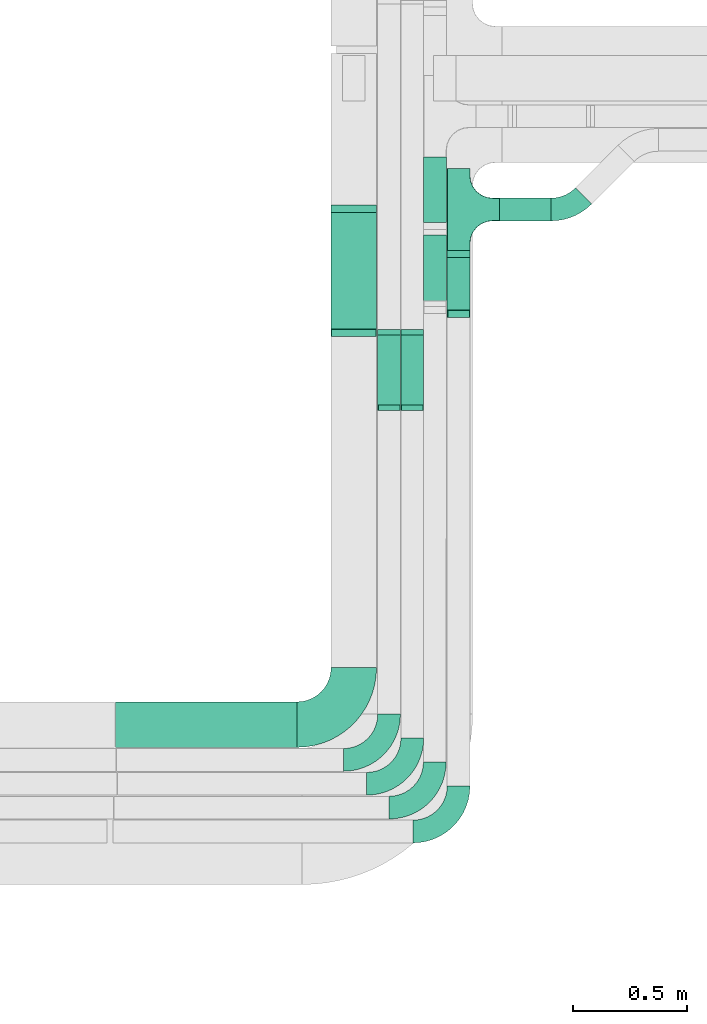
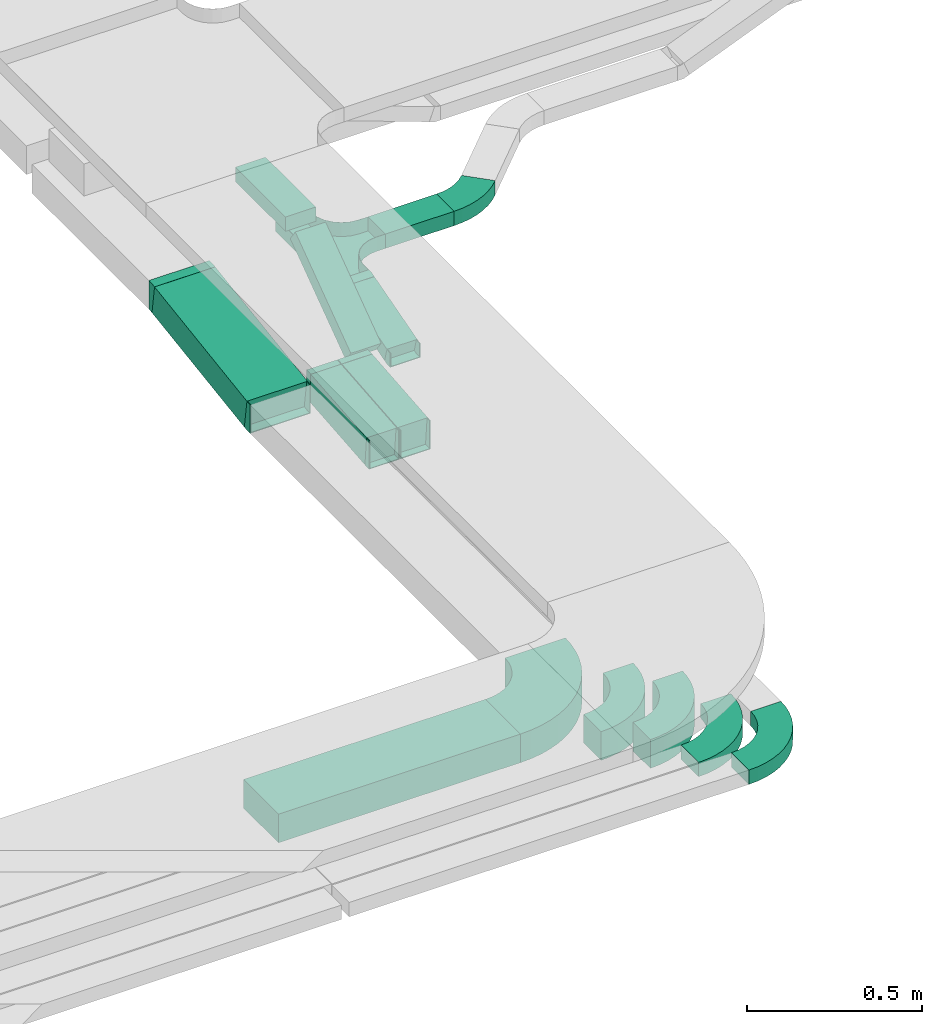
# One storey, part 30 of 38: 15 flow fittings, 8 flow segments.
"""IFC2X3 building model written with IfcOpenShell, lengths in millimetres."""

from ifc_helpers import new_model, entity, si_unit, converted_unit, derived_unit, direction, frame, frame_2d, origin, origin_2d_with_axis, place, context, subcontext, project, spatial, polyline, circle_curve, parameter, trimmed, segment, composite_curve, rectangle, outline, extrude, faceted_brep, source, transform, mapped, material, type_object, type_shapes, element, save


model = new_model("IFC2X3")

# Units and contexts
model_context = context("Model", 3, precision=0.01, world=origin(), true_north=direction((6.12303176911189e-17, 1.0)))
body_context = subcontext(model_context, "Body", "Model", "MODEL_VIEW")
ifc_project = project(units=[si_unit("LENGTHUNIT", "METRE", prefix="MILLI"), si_unit("AREAUNIT", "SQUARE_METRE"), si_unit("VOLUMEUNIT", "CUBIC_METRE"), converted_unit("PLANEANGLEUNIT", "DEGREE", entity("IfcRatioMeasure", 0.0174532925199433), si_unit("PLANEANGLEUNIT", "RADIAN"), dimensions=[0, 0, 0, 0, 0, 0, 0]), si_unit("MASSUNIT", "GRAM", prefix="KILO"), derived_unit("MASSDENSITYUNIT", [(si_unit("MASSUNIT", "GRAM", prefix="KILO"), 1), (si_unit("LENGTHUNIT", "METRE"), -3)]), derived_unit("MOMENTOFINERTIAUNIT", [(si_unit("LENGTHUNIT", "METRE"), 4)]), si_unit("TIMEUNIT", "SECOND"), si_unit("FREQUENCYUNIT", "HERTZ"), si_unit("THERMODYNAMICTEMPERATUREUNIT", "DEGREE_CELSIUS"), derived_unit("THERMALTRANSMITTANCEUNIT", [(si_unit("MASSUNIT", "GRAM", prefix="KILO"), 1), (si_unit("THERMODYNAMICTEMPERATUREUNIT", "KELVIN"), -1), (si_unit("TIMEUNIT", "SECOND"), -3)]), derived_unit("VOLUMETRICFLOWRATEUNIT", [(si_unit("LENGTHUNIT", "METRE"), 3), (si_unit("TIMEUNIT", "SECOND"), -1)]), derived_unit("MASSFLOWRATEUNIT", [(si_unit("MASSUNIT", "GRAM", prefix="KILO"), 1), (si_unit("TIMEUNIT", "SECOND"), -1)]), derived_unit("ROTATIONALFREQUENCYUNIT", [(si_unit("TIMEUNIT", "SECOND"), -1)]), si_unit("ELECTRICCURRENTUNIT", "AMPERE"), si_unit("ELECTRICVOLTAGEUNIT", "VOLT"), si_unit("POWERUNIT", "WATT"), si_unit("FORCEUNIT", "NEWTON", prefix="KILO"), si_unit("ILLUMINANCEUNIT", "LUX"), si_unit("LUMINOUSFLUXUNIT", "LUMEN"), si_unit("LUMINOUSINTENSITYUNIT", "CANDELA"), derived_unit("USERDEFINED", [(si_unit("MASSUNIT", "GRAM", prefix="KILO"), -1), (si_unit("LENGTHUNIT", "METRE"), -2), (si_unit("TIMEUNIT", "SECOND"), 3), (si_unit("LUMINOUSFLUXUNIT", "LUMEN"), 1)]), derived_unit("LINEARVELOCITYUNIT", [(si_unit("LENGTHUNIT", "METRE"), 1), (si_unit("TIMEUNIT", "SECOND"), -1)]), si_unit("PRESSUREUNIT", "PASCAL"), derived_unit("USERDEFINED", [(si_unit("LENGTHUNIT", "METRE"), -2), (si_unit("MASSUNIT", "GRAM", prefix="KILO"), 1), (si_unit("TIMEUNIT", "SECOND"), -2)]), derived_unit("LINEARFORCEUNIT", [(si_unit("MASSUNIT", "GRAM", prefix="KILO"), 1), (si_unit("LENGTHUNIT", "METRE"), 1), (si_unit("TIMEUNIT", "SECOND"), -2), (si_unit("LENGTHUNIT", "METRE"), -1)]), derived_unit("PLANARFORCEUNIT", [(si_unit("MASSUNIT", "GRAM", prefix="KILO"), 1), (si_unit("LENGTHUNIT", "METRE"), 1), (si_unit("TIMEUNIT", "SECOND"), -2), (si_unit("LENGTHUNIT", "METRE"), -2)])], contexts=[model_context])

# Site, building, storey
site_placement = place(None, frame((0.0, -0.00077364408347762, 0.0)))
site = spatial("IfcSite", under=ifc_project, at=site_placement, CompositionType="ELEMENT")
building_placement = place(site_placement, origin())
building = spatial("IfcBuilding", under=site, at=building_placement, CompositionType="ELEMENT")
storey_placement = place(building_placement, frame((0.0, 0.0, 4200.0)))
storey = spatial("IfcBuildingStorey", under=building, at=storey_placement, CompositionType="ELEMENT", Elevation=4200.0)

# Flow segments
cable_carrier_segment_type = type_object("IfcCableCarrierSegmentType", PredefinedType="CABLETRAYSEGMENT")
flow_segment_1_placement = place(storey_placement, frame((60521.4530273012, 5820.36768039066, 2500.0)))
element("IfcFlowSegment", 1, at=flow_segment_1_placement, inside=storey, type_object=cable_carrier_segment_type, context=body_context, shape_type="SweptSolid", body=[
    extrude(rectangle(XDim=798.730000005086, YDim=200.0, at=frame_2d((0.0, -5.47117906535277e-13), x_axis=(1.0, 0.0))), frame((399.365000002543, 100.0, 0.0)), (0.0, 0.0, 1.0), 99.9999999999989),
])
flow_segment_2_placement = place(storey_placement, frame((61982.1830273061, 7730.19297696232, 2504.47725110402)))
element("IfcFlowSegment", 2, at=flow_segment_2_placement, inside=storey, type_object=cable_carrier_segment_type, context=body_context, shape_type="SweptSolid", body=[
    extrude(rectangle(XDim=49.9999999999994, YDim=255.01050846726, at=frame_2d((-6.60804744256893e-13, -3.69482222595252e-13), x_axis=(0.0, 1.0))), frame((0.0, 129.456850821088, 59.1767535282115), z_axis=(1.0, 0.0, 0.0), x_axis=(0.0, 0.961261695938266, 0.275637355817185)), (0.0, 0.0, 1.0), 99.9999999999945),
])
flow_segment_3_placement = place(storey_placement, frame((61878.3352641976, 8130.36201332961, 2757.63390080053)))
element("IfcFlowSegment", 3, at=flow_segment_3_placement, inside=storey, type_object=cable_carrier_segment_type, context=body_context, shape_type="SweptSolid", body=[
    extrude(rectangle(XDim=287.085953827233, YDim=99.9999999999946, at=frame_2d((-5.40012479177676e-13, 0.0), x_axis=(1.0, 0.0))), frame((50.0, 143.543000678446, 6.8225538865363e-05), z_axis=(0.0, -4.75296948219352e-07, 1.0), x_axis=(0.0, -1.0, -4.75296948219352e-07)), (0.0, 0.0, 1.0), 49.9999999999943),
])
flow_segment_4_placement = place(storey_placement, frame((61878.3352641976, 7756.69685752095, 2518.21756635997)))
element("IfcFlowSegment", 4, at=flow_segment_4_placement, inside=storey, type_object=cable_carrier_segment_type, context=body_context, shape_type="SweptSolid", body=[
    extrude(rectangle(XDim=50.0000000000008, YDim=392.571805962097, at=frame_2d((-4.40536496171262e-13, 3.19744231092045e-13), x_axis=(0.0, 1.0))), frame((0.0, 173.493262575214, 135.599383864544), z_axis=(1.0, 0.0, 0.0), x_axis=(0.0, -0.809016994374955, -0.587785252292463)), (0.0, 0.0, 1.0), 99.9999999999946),
])
flow_segment_5_placement = place(storey_placement, frame((61778.6830273062, 7317.30512280422, 2501.08924105085)))
element("IfcFlowSegment", 5, at=flow_segment_5_placement, inside=storey, type_object=cable_carrier_segment_type, context=body_context, shape_type="SweptSolid", body=[
    extrude(rectangle(XDim=99.9999999999994, YDim=99.9999999999946, at=frame_2d((0.0, 5.32907051820075e-14), x_axis=(0.0, 1.0))), frame((50.0, 4.5268117197936, 49.794658103591), z_axis=(0.0, 0.995893162071827, 0.0905362343958401), x_axis=(-1.0, 0.0, 0.0)), (0.0, 0.0, 1.0), 319.917187827381),
])
flow_segment_6_placement = place(storey_placement, frame((61676.2835022257, 7317.30086783851, 2501.08924105085)))
element("IfcFlowSegment", 6, at=flow_segment_6_placement, inside=storey, type_object=cable_carrier_segment_type, context=body_context, shape_type="SweptSolid", body=[
    extrude(rectangle(XDim=99.9999999999994, YDim=99.9999999999946, at=frame_2d((0.0, 5.32907051820075e-14), x_axis=(0.0, 1.0))), frame((50.0, 4.52681171979143, 49.7946581035921), z_axis=(0.0, 0.995893162071827, 0.0905362343958401), x_axis=(-1.0, 0.0, 0.0)), (0.0, 0.0, 1.0), 319.925697831031),
])
flow_segment_7_placement = place(storey_placement, frame((61471.1830273063, 7645.6392623105, 2502.43623020296)))
element("IfcFlowSegment", 7, at=flow_segment_7_placement, inside=storey, type_object=cable_carrier_segment_type, context=body_context, shape_type="SweptSolid", body=[
    extrude(rectangle(XDim=99.9999999999998, YDim=533.962924663429, at=frame_2d((0.0, 0.0), x_axis=(0.0, 1.0))), frame((0.0, 271.43744470685, 88.8637697970419), z_axis=(1.0, 0.0, 0.0), x_axis=(0.0, 0.989044291278135, 0.147619070211579)), (0.0, 0.0, 1.0), 200.000000000006),
])
flow_segment_8_placement = place(storey_placement, frame((62212.1830273061, 8137.18210775869, 2577.30800926447)))
element("IfcFlowSegment", 8, at=flow_segment_8_placement, inside=storey, type_object=cable_carrier_segment_type, context=body_context, shape_type="SweptSolid", body=[
    extrude(rectangle(XDim=226.520887797976, YDim=99.9999999999989, at=origin_2d_with_axis()), frame((113.260443898988, 50.0, 0.0)), (0.0, 0.0, 1.0), 49.9999999999995),
])

# Flow fittings
ifc_material = material()
cable_carrier_fitting_type_1 = type_object("IfcCableCarrierFittingType", Name="470_DKC_S5_Variable Angle Elbow 0-45:-", PredefinedType="NOTDEFINED", material=ifc_material)
shared_shape_1 = source(origin(), body_context, "Body", "SweptSolid", [
    extrude(outline(composite_curve([segment(polyline([(-125.750000000001, -225.25), (-124.749999999999, -225.25)]), True, "CONTINUOUS"), segment(trimmed(circle_curve(frame_2d((-124.75, 124.75), x_axis=(0.0, -1.0)), 350.0), [parameter(0.0)], [parameter(90.0000000000001)], True, "PARAMETER"), True, "CONTINUOUS"), segment(polyline([(225.25, 124.75), (225.25, 125.749999999999)]), True, "CONTINUOUS"), segment(polyline([(225.25, 125.749999999999), (25.25, 125.750000000001)]), True, "CONTINUOUS"), segment(polyline([(25.25, 125.750000000001), (25.25, 124.75)]), True, "CONTINUOUS"), segment(trimmed(circle_curve(frame_2d((-124.75, 124.75), x_axis=(0.0, -1.0)), 150.0), [parameter(0.0)], [parameter(90.0000000000001)], True, "PARAMETER"), False, "CONTINUOUS"), segment(polyline([(-124.749999999999, -25.2500000000003), (-125.750000000001, -25.2500000000003)]), True, "CONTINUOUS"), segment(polyline([(-125.750000000001, -25.2500000000003), (-125.750000000001, -225.25)]), True, "CONTINUOUS")], self_intersect=False)), frame((-125.249999999991, 125.249999999992, -50.0)), (0.0, 0.0, 1.0), 100.0),
])
type_shapes(cable_carrier_fitting_type_1, [shared_shape_1])
flow_fitting_1_placement = place(storey_placement, frame((61571.1830273063, 5920.36768039068, 2550.0)))
element("IfcFlowFitting", 9, at=flow_fitting_1_placement, inside=storey, type_object=cable_carrier_fitting_type_1, material=ifc_material, Name="470_DKC_S5_Variable Angle Elbow 0-45:-", ObjectType="470_DKC_S5_Variable Angle Elbow 0-45:-", context=body_context, shape_type="MappedRepresentation", body=[
    mapped(shared_shape_1, transform((0.0, 0.0, 0.0), scale=1.0)),
])
cable_carrier_fitting_type_2 = type_object("IfcCableCarrierFittingType", Name="470_DKC_S5_Variable Angle Elbow 0-45:-", PredefinedType="NOTDEFINED", material=ifc_material)
shared_shape_2 = source(origin(), body_context, "Body", "SweptSolid", [
    extrude(outline(composite_curve([segment(polyline([(-100.749999999999, -150.250000000001), (-99.7499999999981, -150.250000000001)]), True, "CONTINUOUS"), segment(trimmed(circle_curve(frame_2d((-99.7500000000006, 99.7499999999987), x_axis=(0.0, -1.0)), 250.0), [parameter(0.0)], [parameter(90.0000000000001)], True, "PARAMETER"), True, "CONTINUOUS"), segment(polyline([(150.249999999999, 99.7500000000013), (150.249999999999, 100.750000000001)]), True, "CONTINUOUS"), segment(polyline([(150.249999999999, 100.750000000001), (50.2499999999992, 100.750000000001)]), True, "CONTINUOUS"), segment(polyline([(50.2499999999992, 100.750000000001), (50.2499999999992, 99.7500000000002)]), True, "CONTINUOUS"), segment(trimmed(circle_curve(frame_2d((-99.7500000000006, 99.7499999999987), x_axis=(0.0, -1.0)), 150.0), [parameter(0.0)], [parameter(90.0000000000001)], True, "PARAMETER"), False, "CONTINUOUS"), segment(polyline([(-99.7499999999989, -50.2500000000011), (-100.75, -50.2500000000011)]), True, "CONTINUOUS"), segment(polyline([(-100.75, -50.2500000000011), (-100.749999999999, -150.250000000001)]), True, "CONTINUOUS")], self_intersect=False)), frame((-100.249999999991, 100.249999999992, -50.0)), (0.0, 0.0, 1.0), 100.0),
])
type_shapes(cable_carrier_fitting_type_2, [shared_shape_2])
for number, where, name in (
    (10, (61828.6830273062, 5660.19378076407, 2550.0), "470_DKC_S5_Variable Angle Elbow 0-45:-"),
    (11, (61726.2835022257, 5765.19378076406, 2550.0), "470_DKC_S5_Variable Angle Elbow 0-45:-"),
):
    element("IfcFlowFitting", number, at=place(storey_placement, frame(where)), inside=storey, type_object=cable_carrier_fitting_type_2, material=ifc_material, Name=name, ObjectType="470_DKC_S5_Variable Angle Elbow 0-45:-", context=body_context, shape_type="MappedRepresentation", body=[
        mapped(shared_shape_2, transform((0.0, 0.0, 0.0), scale=1.0)),
    ])
cable_carrier_fitting_type_3 = type_object("IfcCableCarrierFittingType", PredefinedType="NOTDEFINED", material=ifc_material)
shared_shape_3 = source(origin(), body_context, "Body", "Brep", [
    faceted_brep([(-53.4074173710859, -124.118095489752, 25.0), (-50.0, -150.0, 25.0), (-50.0, -180.0, 25.0), (-49.1999999999934, -180.0, 25.0), (-49.1999999999926, -150.0, 25.0), (-52.6346767100545, -123.91104025367, 25.0), (-62.7046392985216, -99.6000000000037, 25.0), (-78.7236364563899, -78.7236364563991, 25.0), (-99.5999999999949, -62.7046392985315, 25.0), (-123.911040253662, -52.6346767100651, 25.0), (-150.0, -49.2000000000047, 25.0), (-180.0, -49.2000000000047, 25.0), (-180.0, -50.0, 25.0), (-150.0, -50.0, 25.0), (-124.118095489745, -53.4074173710983, 25.0), (-100.0, -63.3974596215602, 25.0), (-79.2893218813398, -79.2893218813488, 25.0), (-63.3974596215496, -100.0, 25.0), (180.0, -50.0, 25.0), (180.0, -49.2000000000047, 25.0), (150.0, -49.2000000000046, 25.0), (123.911040253717, -52.634676710066, 25.0), (99.6000000000452, -62.7046392985316, 25.0), (78.7236364564342, -78.7236364563979, 25.0), (62.7046392985581, -99.6000000000012, 25.0), (52.6346767100809, -123.911040253668, 25.0), (49.200000000007, -150.0, 25.0), (49.2000000000071, -180.0, 25.0), (50.0, -180.0, 25.0), (50.0, -150.0, 25.0), (53.4074173711136, -124.11809548975, 25.0), (63.3974596215874, -100.0, 25.0), (79.2893218813853, -79.2893218813486, 25.0), (100.0, -63.3974596215613, 25.0), (124.1180954898, -53.4074173710999, 25.0), (150.0, -50.0, 25.0), (180.0, 49.1999999999958, 25.0), (180.0, 50.0, 25.0), (-180.0, 50.0, 25.0), (-180.0, 49.1999999999958, 25.0), (-180.0, -50.0, -25.0), (-180.0, 50.0, -25.0), (180.0, 50.0, -25.0), (180.0, -50.0, -25.0), (150.0, -50.0, -25.0), (124.1180954898, -53.4074173710999, -25.0), (100.0, -63.3974596215613, -25.0), (79.2893218813853, -79.2893218813486, -25.0), (63.3974596215874, -100.0, -25.0), (53.4074173711136, -124.11809548975, -25.0), (50.0, -150.0, -25.0), (50.0, -180.0, -25.0), (-50.0, -180.0, -25.0), (-50.0, -150.0, -25.0), (-53.4074173710859, -124.118095489752, -25.0), (-63.3974596215496, -100.0, -25.0), (-79.2893218813398, -79.2893218813488, -25.0), (-100.0, -63.3974596215602, -25.0), (-124.118095489745, -53.4074173710983, -25.0), (-150.0, -50.0, -25.0), (-50.0, -150.0, -24.199999999986), (49.2000000000071, -180.0, -24.199999999986), (-49.1999999999934, -180.0, -24.199999999986), (-49.1999999999926, -150.0, -24.199999999986), (-150.0, -49.2000000000047, -24.199999999986), (-180.0, -49.2000000000047, -24.199999999986), (180.0, -49.2000000000047, -24.199999999986), (150.0, -49.2000000000047, -24.199999999986), (-180.0, 49.1999999999958, -24.199999999986), (-150.0, -50.0, -24.199999999986), (150.0, -50.0, -24.199999999986), (180.0, 49.1999999999958, -24.199999999986), (49.200000000007, -150.0, -24.199999999986), (50.0, -150.0, -24.199999999986), (-123.911040253662, -52.6346767100651, -24.199999999986), (-99.5999999999949, -62.7046392985315, -24.199999999986), (-78.7236364563899, -78.7236364563991, -24.199999999986), (-62.7046392985217, -99.6000000000036, -24.199999999986), (-52.6346767100546, -123.91104025367, -24.199999999986), (52.6346767100807, -123.911040253669, -24.199999999986), (62.7046392985577, -99.6000000000018, -24.199999999986), (78.7236364564338, -78.7236364563983, -24.199999999986), (99.6000000000446, -62.704639298532, -24.199999999986), (123.911040253716, -52.6346767100662, -24.199999999986)], [[[0, 1, 2, 3, 4, 5, 6, 7, 8, 9, 10, 11, 12, 13, 14, 15, 16, 17]], [[18, 19, 20, 21, 22, 23, 24, 25, 26, 27, 28, 29, 30, 31, 32, 33, 34, 35]], [[36, 37, 38, 39]], [[40, 41, 42, 43, 44, 45, 46, 47, 48, 49, 50, 51, 52, 53, 54, 55, 56, 57, 58, 59]], [[2, 1, 60, 53, 52]], [[3, 2, 52, 51, 28, 27, 61, 62]], [[4, 3, 62, 63]], [[11, 10, 64, 65]], [[20, 19, 66, 67]], [[39, 38, 41, 40, 12, 11, 65, 68]], [[13, 12, 40, 59, 69]], [[18, 35, 70, 44, 43]], [[19, 18, 43, 42, 37, 36, 71, 66]], [[27, 26, 72, 61]], [[29, 28, 51, 50, 73]], [[38, 37, 42, 41]], [[36, 39, 68, 71]], [[68, 65, 64, 74, 75, 76, 77, 78, 63, 62, 61, 72, 79, 80, 81, 82, 83, 67, 66, 71]], [[14, 13, 69, 59, 58]], [[58, 57, 15, 14]], [[15, 57, 56, 16]], [[0, 17, 55, 54]], [[0, 54, 53, 60, 1]], [[55, 17, 16, 56]], [[5, 4, 63, 78]], [[6, 5, 78, 77]], [[7, 6, 77, 76]], [[8, 7, 76, 75]], [[9, 8, 75, 74]], [[10, 9, 74, 64]], [[21, 20, 67, 83]], [[22, 21, 83, 82]], [[23, 22, 82, 81]], [[81, 80, 24, 23]], [[24, 80, 79, 25]], [[79, 72, 26, 25]], [[30, 29, 73, 50, 49]], [[31, 30, 49, 48]], [[31, 48, 47, 32]], [[33, 32, 47, 46]], [[45, 34, 33, 46]], [[34, 45, 44, 70, 35]]]),
])
type_shapes(cable_carrier_fitting_type_3, [shared_shape_3])
flow_fitting_2_placement = place(storey_placement, frame((62032.1830273061, 8187.18210775868, 2602.30800926447), z_axis=(0.0, 0.0, 1.0), x_axis=(0.0, 1.0, 0.0)))
element("IfcFlowFitting", 12, at=flow_fitting_2_placement, inside=storey, type_object=cable_carrier_fitting_type_3, material=ifc_material, Name="470_DKC_S5_T", context=body_context, shape_type="MappedRepresentation", body=[
    mapped(shared_shape_3, transform((0.0, 0.0, 0.0), scale=1.0)),
])
cable_carrier_fitting_type_4 = type_object("IfcCableCarrierFittingType", Name="470_DKC_S5_Variable Angle Elbow 0-45:-", PredefinedType="NOTDEFINED", material=ifc_material)
shared_shape_4 = source(origin(), body_context, "Body", "SweptSolid", [
    extrude(outline(composite_curve([segment(polyline([(-100.750000000001, -150.25), (-99.7499999999994, -150.25)]), True, "CONTINUOUS"), segment(trimmed(circle_curve(frame_2d((-99.7499999999997, 99.7499999999995), x_axis=(0.0, -1.0)), 250.0), [parameter(0.0)], [parameter(90.0000000000001)], True, "PARAMETER"), True, "CONTINUOUS"), segment(polyline([(150.25, 99.75), (150.25, 100.749999999999)]), True, "CONTINUOUS"), segment(polyline([(150.25, 100.749999999999), (50.25, 100.75)]), True, "CONTINUOUS"), segment(polyline([(50.25, 100.75), (50.25, 99.7499999999998)]), True, "CONTINUOUS"), segment(trimmed(circle_curve(frame_2d((-99.7499999999997, 99.7499999999995), x_axis=(0.0, -1.0)), 150.0), [parameter(0.0)], [parameter(90.0000000000001)], True, "PARAMETER"), False, "CONTINUOUS"), segment(polyline([(-99.7499999999994, -50.2500000000003), (-100.750000000001, -50.2500000000003)]), True, "CONTINUOUS"), segment(polyline([(-100.750000000001, -50.2500000000003), (-100.750000000001, -150.25)]), True, "CONTINUOUS")], self_intersect=False)), frame((-100.249999999991, 100.249999999992, -25.0)), (0.0, 0.0, 1.0), 49.9999999999997),
])
type_shapes(cable_carrier_fitting_type_4, [shared_shape_4])
flow_fitting_3_placement = place(storey_placement, frame((62032.1830273061, 5450.19378076406, 2525.0)))
element("IfcFlowFitting", 13, at=flow_fitting_3_placement, inside=storey, type_object=cable_carrier_fitting_type_4, material=ifc_material, Name="470_DKC_S5_Variable Angle Elbow 0-45:-", ObjectType="470_DKC_S5_Variable Angle Elbow 0-45:-", context=body_context, shape_type="MappedRepresentation", body=[
    mapped(shared_shape_4, transform((0.0, 0.0, 0.0), scale=1.0)),
])
cable_carrier_fitting_type_5 = type_object("IfcCableCarrierFittingType", PredefinedType="NOTDEFINED", material=ifc_material)
shared_shape_5 = source(origin(), body_context, "Body", "Brep", [
    faceted_brep([(-12.7297459086367, -25.0, 50.0), (-12.7297459086365, 25.0, 50.0), (-12.7297459086365, 25.0, 47.4600000101635), (-12.7297459086366, -22.46000001016, 47.4600000101635), (-12.7297459086366, -22.46000001016, -47.4600000101565), (-12.7297459086365, 25.0, -47.4600000101565), (-12.7297459086365, 25.0, -50.0), (-12.7297459086367, -25.0, -50.0), (19.1275510364297, -20.5227488959758, 50.0), (19.1275510364297, -20.5227488959758, -50.0), (5.34568324557039, 27.5403359009375, -50.0), (5.34568324557039, 27.5403359009375, -47.4600000101565), (18.4274321554545, -18.081144198059, -47.4600000101565), (18.4274321554545, -18.081144198059, 47.4600000101635), (5.34568324557039, 27.5403359009375, 47.4600000101635), (5.34568324557039, 27.5403359009375, 50.0), (3.51352086756263, -25.0, 50.0), (-3.51352086756186, 25.0, 50.0), (-3.51352086756186, 25.0, 47.4600000101635), (3.15654714884614, -22.46000001016, 47.4600000101635), (3.15654714884614, -22.46000001016, -47.4600000101565), (-3.51352086756186, 25.0, -47.4600000101565), (-3.51352086756186, 25.0, -50.0), (3.51352086756256, -25.0, -50.0)], [[[0, 1, 2, 3, 4, 5, 6, 7]], [[8, 9, 10, 11, 12, 13, 14, 15]], [[1, 0, 16, 8, 15, 17]], [[2, 1, 17, 18]], [[3, 2, 18, 14, 13, 19]], [[4, 3, 19, 20]], [[5, 4, 20, 12, 11, 21]], [[6, 5, 21, 22]], [[7, 6, 22, 10, 9, 23]], [[0, 7, 23, 16]], [[18, 17, 15, 14]], [[20, 19, 13, 12]], [[22, 21, 11, 10]], [[16, 23, 9, 8]]]),
])
type_shapes(cable_carrier_fitting_type_5, [shared_shape_5])
for number, where, z_axis, x_axis in (
    (14, (62032.1830273061, 7994.45236185007, 2602.30800926447), (1.0, 0.0, 0.0), (0.0, -1.0, 0.0)),
    (15, (62032.1830273061, 7724.84729371675, 2525.0), (-1.0, 0.0, 0.0), (0.0, -0.96126169593834, -0.275637355816927)),
):
    element("IfcFlowFitting", number, at=place(storey_placement, frame(where, z_axis=z_axis, x_axis=x_axis)), inside=storey, type_object=cable_carrier_fitting_type_5, material=ifc_material, context=body_context, shape_type="MappedRepresentation", body=[
        mapped(shared_shape_5, transform((0.0, 0.0, 0.0), scale=1.0)),
    ])
cable_carrier_fitting_type_6 = type_object("IfcCableCarrierFittingType", Name="470_DKC_S5_Variable Angle Elbow 0-45:-", PredefinedType="NOTDEFINED", material=ifc_material)
shared_shape_6 = source(origin(), body_context, "Body", "SweptSolid", [
    extrude(outline(composite_curve([segment(polyline([(-100.750103540937, -150.204430433162), (-99.7501035409357, -150.204430433162)]), True, "CONTINUOUS"), segment(trimmed(circle_curve(frame_2d((-99.7501035409361, 99.7955695668373), x_axis=(0.0, -1.0)), 250.0), [parameter(0.0)], [parameter(89.9738905754284)], True, "PARAMETER"), True, "CONTINUOUS"), segment(polyline([(150.249870501774, 99.6816457146365), (150.250326197183, 100.681645610807)]), True, "CONTINUOUS"), segment(polyline([(150.250326197183, 100.681645610807), (50.2503365800987, 100.727215151688)]), True, "CONTINUOUS"), segment(polyline([(50.2503365800987, 100.727215151688), (50.2498808846899, 99.7272152555168)]), True, "CONTINUOUS"), segment(trimmed(circle_curve(frame_2d((-99.7501035409361, 99.7955695668373), x_axis=(0.0, -1.0)), 150.0), [parameter(0.0)], [parameter(89.9738905754284)], True, "PARAMETER"), False, "CONTINUOUS"), segment(polyline([(-99.7501035409357, -50.2044304331625), (-100.750103540937, -50.2044304331625)]), True, "CONTINUOUS"), segment(polyline([(-100.750103540937, -50.2044304331625), (-100.750103540937, -150.204430433162)]), True, "CONTINUOUS")], self_intersect=False)), frame((-100.158778133664, 100.204430433154, -25.0)), (0.0, 0.0, 1.0), 49.9999999999997),
])
type_shapes(cable_carrier_fitting_type_6, [shared_shape_6])
flow_fitting_4_placement = place(storey_placement, frame((61927.337021041, 5555.19585792169, 2525.0)))
element("IfcFlowFitting", 16, at=flow_fitting_4_placement, inside=storey, type_object=cable_carrier_fitting_type_6, material=ifc_material, Name="470_DKC_S5_Variable Angle Elbow 0-45:-", ObjectType="470_DKC_S5_Variable Angle Elbow 0-45:-", context=body_context, shape_type="MappedRepresentation", body=[
    mapped(shared_shape_6, transform((0.0, 0.0, 0.0), scale=1.0)),
])
cable_carrier_fitting_type_7 = type_object("IfcCableCarrierFittingType", PredefinedType="NOTDEFINED", material=ifc_material)
shared_shape_7 = source(origin(), body_context, "Body", "Brep", [
    faceted_brep([(-9.76293260191559, -50.0, 50.0), (-9.76293260191527, 50.0, 50.0), (-9.76293260191527, 50.0, 47.4600000101635), (-9.76293260191559, -47.46000001016, 47.4600000101635), (-9.76293260191559, -47.46000001016, -47.4600000101565), (-9.76293260191527, 50.0, -47.4600000101565), (-9.76293260191527, 50.0, -50.0), (-9.76293260191559, -50.0, -50.0), (14.2496495398129, -48.9107589491527, 50.0), (14.2496495398129, -48.9107589491527, -50.0), (5.19602610021986, 50.6785572580292, -50.0), (5.19602610021986, 50.6785572580292, -47.4600000101565), (14.0196875053671, -46.3811903276085, -47.4600000101565), (14.0196875053671, -46.3811903276086, 47.4600000101635), (5.19602610021986, 50.6785572580292, 47.4600000101635), (5.19602610021986, 50.6785572580292, 50.0), (2.26806314376965, -50.0, 50.0), (-2.26806314376892, 50.0, 50.0), (-2.26806314376892, 50.0, 47.4600000101635), (2.15284553652702, -47.46000001016, 47.4600000101635), (2.15284553652702, -47.46000001016, -47.4600000101565), (-2.26806314376892, 50.0, -47.4600000101565), (-2.26806314376892, 50.0, -50.0), (2.26806314376963, -50.0, -50.0)], [[[0, 1, 2, 3, 4, 5, 6, 7]], [[8, 9, 10, 11, 12, 13, 14, 15]], [[1, 0, 16, 8, 15, 17]], [[2, 1, 17, 18]], [[3, 2, 18, 14, 13, 19]], [[4, 3, 19, 20]], [[5, 4, 20, 12, 11, 21]], [[6, 5, 21, 22]], [[7, 6, 22, 10, 9, 23]], [[0, 7, 23, 16]], [[18, 17, 15, 14]], [[20, 19, 13, 12]], [[22, 21, 11, 10]], [[16, 23, 9, 8]]]),
])
type_shapes(cable_carrier_fitting_type_7, [shared_shape_7])
for number, where, z_axis, x_axis in (
    (17, (61828.6830273062, 7312.109096704, 2550.0), (1.0, 0.0, 0.0), (0.0, 1.0, 0.0)),
    (18, (61828.6830273062, 7650.15811213057, 2580.73189581328), (-1.0, 0.0, 0.0), (0.0, 0.995893162071827, 0.090536234395836)),
    (19, (61726.2835022257, 7650.1623322193, 2580.73266627696), (-1.0, 0.0, 0.0), (0.0, 0.995893162071827, 0.0905362343958338)),
    (20, (61726.2835022257, 7312.10484173829, 2550.0), (-1.0, 0.0, 0.0), (0.0, -0.995893162071818, -0.09053623439593)),
):
    element("IfcFlowFitting", number, at=place(storey_placement, frame(where, z_axis=z_axis, x_axis=x_axis)), inside=storey, type_object=cable_carrier_fitting_type_7, material=ifc_material, context=body_context, shape_type="MappedRepresentation", body=[
        mapped(shared_shape_7, transform((0.0, 0.0, 0.0), scale=1.0)),
    ])
cable_carrier_fitting_type_8 = type_object("IfcCableCarrierFittingType", PredefinedType="NOTDEFINED", material=ifc_material)
shared_shape_8 = source(origin(), body_context, "Body", "Brep", [
    faceted_brep([(-12.7926883982631, -50.0, 100.0), (-12.7926883982628, 50.0, 100.0), (-12.7926883982628, 50.0, 97.4600000101635), (-12.7926883982631, -47.46000001016, 97.4600000101635), (-12.7926883982631, -47.46000001016, -97.4600000101564), (-12.7926883982628, 50.0, -97.4600000101564), (-12.7926883982628, 50.0, -100.0), (-12.7926883982631, -50.0, -100.0), (20.0334889410087, -47.5637697970378, 100.0), (20.0334889410087, -47.5637697970378, -100.0), (5.27158191979488, 51.3406593307674, -100.0), (5.27158191979488, 51.3406593307674, -97.4600000101564), (19.6585365041697, -45.0515973072403, -97.4600000101564), (19.6585365041697, -45.0515973072403, 97.4600000101635), (5.27158191979488, 51.3406593307674, 97.4600000101635), (5.27158191979488, 51.3406593307674, 100.0), (3.71080399917335, -50.0, 100.0), (-3.71080399917263, 50.0, 100.0), (-3.71080399917263, 50.0, 97.4600000101635), (3.52229515676936, -47.46000001016, 97.4600000101635), (3.52229515676936, -47.46000001016, -97.4600000101564), (-3.71080399917263, 50.0, -97.4600000101564), (-3.71080399917263, 50.0, -100.0), (3.71080399917331, -50.0, -100.0)], [[[0, 1, 2, 3, 4, 5, 6, 7]], [[8, 9, 10, 11, 12, 13, 14, 15]], [[1, 0, 16, 8, 15, 17]], [[2, 1, 17, 18]], [[3, 2, 18, 14, 13, 19]], [[4, 3, 19, 20]], [[5, 4, 20, 12, 11, 21]], [[6, 5, 21, 22]], [[7, 6, 22, 10, 9, 23]], [[0, 7, 23, 16]], [[18, 17, 15, 14]], [[20, 19, 13, 12]], [[22, 21, 11, 10]], [[16, 23, 9, 8]]]),
])
type_shapes(cable_carrier_fitting_type_8, [shared_shape_8])
for number, where, z_axis, x_axis in (
    (21, (61571.1830273063, 7640.36768039067, 2550.0), (1.0, 0.0, 0.0), (0.0, 1.0, 0.0)),
    (22, (61571.1830273063, 8193.78573364402, 2632.6), (1.0, 0.0, 0.0), (0.0, -1.0, 0.0)),
):
    element("IfcFlowFitting", number, at=place(storey_placement, frame(where, z_axis=z_axis, x_axis=x_axis)), inside=storey, type_object=cable_carrier_fitting_type_8, material=ifc_material, context=body_context, shape_type="MappedRepresentation", body=[
        mapped(shared_shape_8, transform((0.0, 0.0, 0.0), scale=1.0)),
    ])
cable_carrier_fitting_type_9 = type_object("IfcCableCarrierFittingType", Name="470_DKC_S5_Variable Angle Elbow 0-45:-", PredefinedType="NOTDEFINED", material=ifc_material)
shared_shape_9 = source(origin(), body_context, "Body", "SweptSolid", [
    extrude(outline(composite_curve([segment(polyline([(-71.6374548139522, -79.4660985766419), (-70.637454813951, -79.4660985766419)]), True, "CONTINUOUS"), segment(trimmed(circle_curve(frame_2d((-70.6374548139513, 170.533901423358), x_axis=(0.0, -1.0)), 250.0), [parameter(0.0)], [parameter(45.0)], True, "PARAMETER"), True, "CONTINUOUS"), segment(polyline([(106.139240482685, -6.24279387327877), (106.846347263872, -5.535687092092)]), True, "CONTINUOUS"), segment(polyline([(106.846347263872, -5.53568709209197), (36.1356691452172, 65.1749910265623)]), True, "CONTINUOUS"), segment(polyline([(36.1356691452171, 65.1749910265622), (35.4285623640307, 64.4678842453758)]), True, "CONTINUOUS"), segment(trimmed(circle_curve(frame_2d((-70.6374548139513, 170.533901423358), x_axis=(0.0, -1.0)), 150.0), [parameter(0.0)], [parameter(45.0)], True, "PARAMETER"), False, "CONTINUOUS"), segment(polyline([(-70.637454813951, 20.5339014233579), (-71.6374548139522, 20.5339014233579)]), True, "CONTINUOUS"), segment(polyline([(-71.6374548139522, 20.5339014233579), (-71.6374548139522, -79.4660985766419)]), True, "CONTINUOUS")], self_intersect=False)), frame((-12.205257660658, 29.4660985766339, -25.0)), (0.0, 0.0, 1.0), 49.9999999999999),
])
type_shapes(cable_carrier_fitting_type_9, [shared_shape_9])
flow_fitting_5_placement = place(storey_placement, frame((62522.5466275787, 8187.18210775871, 2602.30800926447)))
element("IfcFlowFitting", 23, at=flow_fitting_5_placement, inside=storey, type_object=cable_carrier_fitting_type_9, material=ifc_material, Name="470_DKC_S5_Variable Angle Elbow 0-45:-", ObjectType="470_DKC_S5_Variable Angle Elbow 0-45:-", context=body_context, shape_type="MappedRepresentation", body=[
    mapped(shared_shape_9, transform((0.0, 0.0, 0.0), scale=1.0)),
])

save(model, "model.ifc")
